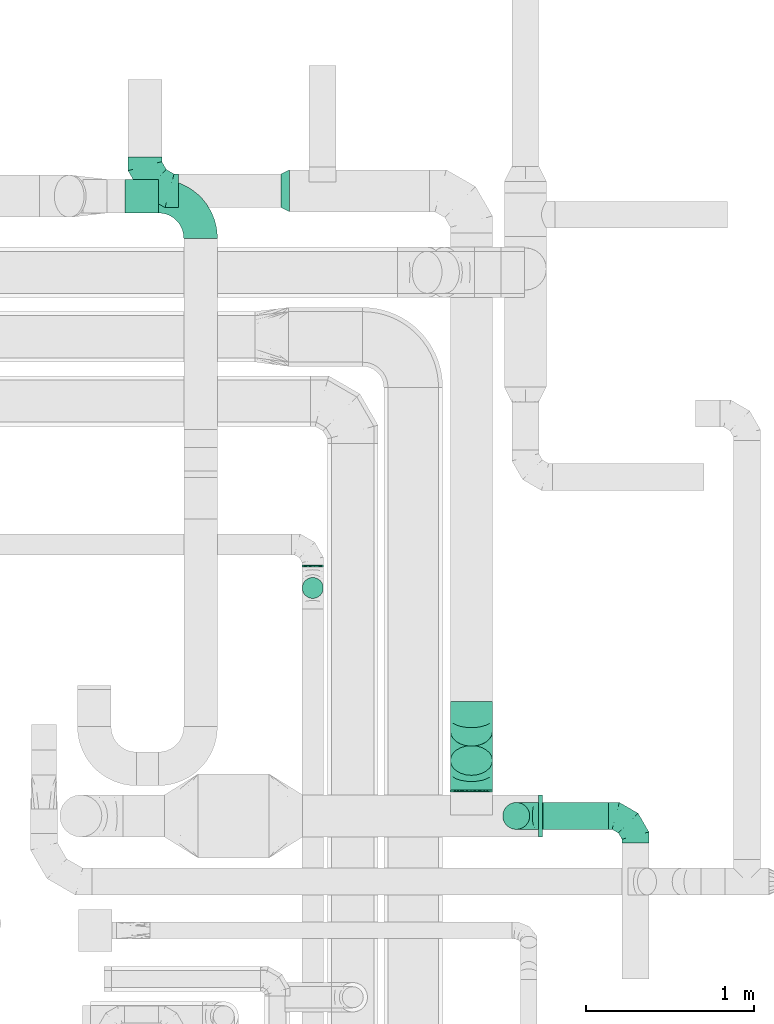
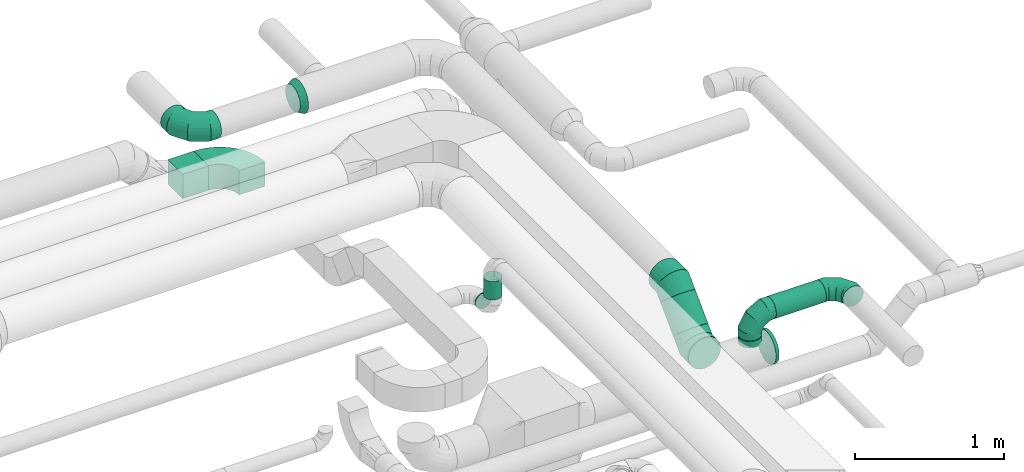
# One storey, part 72 of 92: 9 flow fittings, 7 flow segments.
"""IFC2X3 building model written with IfcOpenShell, lengths in millimetres."""

from ifc_helpers import new_model, entity, si_unit, converted_unit, derived_unit, direction, frame, frame_2d, origin, origin_2d_with_axis, place, context, subcontext, project, spatial, polyline, circle_curve, parameter, trimmed, segment, composite_curve, rectangle, circle, outline, extrude, faceted_brep, source, transform, mapped, material, type_object, type_shapes, element, save


model = new_model("IFC2X3")

# Units and contexts
model_context = context("Model", 3, precision=0.01, world=origin(), true_north=direction((6.12303176911189e-17, 1.0)))
body_context = subcontext(model_context, "Body", "Model", "MODEL_VIEW")
ifc_project = project(units=[si_unit("LENGTHUNIT", "METRE", prefix="MILLI"), si_unit("AREAUNIT", "SQUARE_METRE"), si_unit("VOLUMEUNIT", "CUBIC_METRE"), converted_unit("PLANEANGLEUNIT", "DEGREE", entity("IfcRatioMeasure", 0.0174532925199433), si_unit("PLANEANGLEUNIT", "RADIAN"), dimensions=[0, 0, 0, 0, 0, 0, 0]), si_unit("MASSUNIT", "GRAM", prefix="KILO"), derived_unit("MASSDENSITYUNIT", [(si_unit("MASSUNIT", "GRAM", prefix="KILO"), 1), (si_unit("LENGTHUNIT", "METRE"), -3)]), derived_unit("MOMENTOFINERTIAUNIT", [(si_unit("LENGTHUNIT", "METRE"), 4)]), si_unit("TIMEUNIT", "SECOND"), si_unit("FREQUENCYUNIT", "HERTZ"), si_unit("THERMODYNAMICTEMPERATUREUNIT", "DEGREE_CELSIUS"), derived_unit("THERMALTRANSMITTANCEUNIT", [(si_unit("MASSUNIT", "GRAM", prefix="KILO"), 1), (si_unit("THERMODYNAMICTEMPERATUREUNIT", "KELVIN"), -1), (si_unit("TIMEUNIT", "SECOND"), -3)]), derived_unit("VOLUMETRICFLOWRATEUNIT", [(si_unit("LENGTHUNIT", "METRE"), 3), (si_unit("TIMEUNIT", "SECOND"), -1)]), derived_unit("MASSFLOWRATEUNIT", [(si_unit("MASSUNIT", "GRAM", prefix="KILO"), 1), (si_unit("TIMEUNIT", "SECOND"), -1)]), derived_unit("ROTATIONALFREQUENCYUNIT", [(si_unit("TIMEUNIT", "SECOND"), -1)]), si_unit("ELECTRICCURRENTUNIT", "AMPERE"), si_unit("ELECTRICVOLTAGEUNIT", "VOLT"), si_unit("POWERUNIT", "WATT"), si_unit("FORCEUNIT", "NEWTON", prefix="KILO"), si_unit("ILLUMINANCEUNIT", "LUX"), si_unit("LUMINOUSFLUXUNIT", "LUMEN"), si_unit("LUMINOUSINTENSITYUNIT", "CANDELA"), derived_unit("USERDEFINED", [(si_unit("MASSUNIT", "GRAM", prefix="KILO"), -1), (si_unit("LENGTHUNIT", "METRE"), -2), (si_unit("TIMEUNIT", "SECOND"), 3), (si_unit("LUMINOUSFLUXUNIT", "LUMEN"), 1)]), derived_unit("LINEARVELOCITYUNIT", [(si_unit("LENGTHUNIT", "METRE"), 1), (si_unit("TIMEUNIT", "SECOND"), -1)]), si_unit("PRESSUREUNIT", "PASCAL"), derived_unit("USERDEFINED", [(si_unit("LENGTHUNIT", "METRE"), -2), (si_unit("MASSUNIT", "GRAM", prefix="KILO"), 1), (si_unit("TIMEUNIT", "SECOND"), -2)]), derived_unit("LINEARFORCEUNIT", [(si_unit("MASSUNIT", "GRAM", prefix="KILO"), 1), (si_unit("LENGTHUNIT", "METRE"), 1), (si_unit("TIMEUNIT", "SECOND"), -2), (si_unit("LENGTHUNIT", "METRE"), -1)]), derived_unit("PLANARFORCEUNIT", [(si_unit("MASSUNIT", "GRAM", prefix="KILO"), 1), (si_unit("LENGTHUNIT", "METRE"), 1), (si_unit("TIMEUNIT", "SECOND"), -2), (si_unit("LENGTHUNIT", "METRE"), -2)])], contexts=[model_context])

# Site, building, storey
site_placement = place(None, origin())
site = spatial("IfcSite", under=ifc_project, at=site_placement, CompositionType="ELEMENT")
building_placement = place(site_placement, origin())
building = spatial("IfcBuilding", under=site, at=building_placement, CompositionType="ELEMENT")
storey_placement = place(building_placement, frame((0.0, 0.0, 4200.0)))
storey = spatial("IfcBuildingStorey", under=building, at=storey_placement, CompositionType="ELEMENT", Elevation=4200.0)

# Flow segments
duct_segment_type_1 = type_object("IfcDuctSegmentType", PredefinedType="NOTDEFINED")
flow_segment_1_placement = place(storey_placement, frame((59731.37, 16074.48, 2900.0)))
element("IfcFlowSegment", 1, at=flow_segment_1_placement, inside=storey, type_object=duct_segment_type_1, context=body_context, shape_type="SweptSolid", body=[
    extrude(rectangle(XDim=200.186997811014, YDim=200.0, at=origin_2d_with_axis()), frame((100.09, 100.0, 0.0), z_axis=(0.0, 0.0, 1.0), x_axis=(-1.0, 0.0, 0.0)), (0.0, 0.0, 1.0), 200.0),
])
duct_segment_type_2 = type_object("IfcDuctSegmentType", PredefinedType="NOTDEFINED")
flow_segment_2_placement = place(storey_placement, frame((62215.95, 12412.12, 3228.4)))
element("IfcFlowSegment", 2, at=flow_segment_2_placement, inside=storey, type_object=duct_segment_type_2, context=body_context, shape_type="SweptSolid", body=[
    extrude(circle(Radius=80.0, at=origin_2d_with_axis()), frame((0.0, 81.6, 81.6), z_axis=(1.0, 0.0, 0.0), x_axis=(0.0, 1.0, 0.0)), (0.0, 0.0, 1.0), 388.115615299781),
])
flow_segment_3_placement = place(storey_placement, frame((60783.3, 13972.55, 2885.9)))
element("IfcFlowSegment", 3, at=flow_segment_3_placement, inside=storey, type_object=duct_segment_type_2, context=body_context, shape_type="SweptSolid", body=[
    extrude(circle(Radius=62.5, at=origin_2d_with_axis()), frame((64.1, 0.0, 64.1), z_axis=(0.0, 1.0, 0.0), x_axis=(-1.0, 0.0, 0.0)), (0.0, 0.0, 1.0), 8.73030929463088),
])
flow_segment_4_placement = place(storey_placement, frame((60783.3, 13783.46, 3075.0)))
element("IfcFlowSegment", 4, at=flow_segment_4_placement, inside=storey, type_object=duct_segment_type_2, context=body_context, shape_type="SweptSolid", body=[
    extrude(circle(Radius=62.5, at=origin_2d_with_axis()), frame((64.1, 64.1, 0.0)), (0.0, 0.0, 1.0), 150.000000000007),
])
flow_segment_5_placement = place(storey_placement, frame((61663.4, 12638.72, 2873.4)))
element("IfcFlowSegment", 5, at=flow_segment_5_placement, inside=storey, type_object=duct_segment_type_2, context=body_context, shape_type="SweptSolid", body=[
    extrude(circle(Radius=125.0, at=origin_2d_with_axis()), frame((126.6, 0.0, 126.6), z_axis=(0.0, 1.0, 0.0), x_axis=(1.0, 0.0, 0.0)), (0.0, 0.0, 1.0), 7.53183894146752),
])
flow_segment_6_placement = place(storey_placement, frame((61663.4, 12733.04, 2983.24)))
element("IfcFlowSegment", 6, at=flow_segment_6_placement, inside=storey, type_object=duct_segment_type_2, context=body_context, shape_type="SweptSolid", body=[
    extrude(circle(Radius=125.0, at=origin_2d_with_axis()), frame((126.6, 89.98, 89.98), z_axis=(0.0, 0.707106781186552, 0.707106781186543), x_axis=(1.0, 0.0, 0.0)), (0.0, 0.0, 1.0), 245.442110322462),
])
flow_segment_7_placement = place(storey_placement, frame((61974.35, 12412.12, 3145.0)))
element("IfcFlowSegment", 7, at=flow_segment_7_placement, inside=storey, type_object=duct_segment_type_2, context=body_context, shape_type="SweptSolid", body=[
    extrude(circle(Radius=80.0, at=origin_2d_with_axis()), frame((81.6, 81.6, 0.0), z_axis=(0.0, 0.0, 1.0), x_axis=(0.0, 1.0, 0.0)), (0.0, 0.0, 1.0), 4.99960129249847),
])

# Flow fittings
ifc_material = material()
duct_fitting_type_1 = type_object("IfcDuctFittingType", PredefinedType="NOTDEFINED", material=ifc_material)
shared_shape_1 = source(origin(), body_context, "Body", "SweptSolid", [
    extrude(circle(Radius=124.999999999999, at=origin_2d_with_axis()), frame((0.0, 0.0, 0.0), z_axis=(1.0, 0.0, 0.0), x_axis=(0.0, 1.0, 0.0)), (0.0, 0.0, 1.0), 25.0000000000018),
])
type_shapes(duct_fitting_type_1, [shared_shape_1])
flow_fitting_1_placement = place(storey_placement, frame((62187.28, 12493.72, 3000.0)))
element("IfcFlowFitting", 8, at=flow_fitting_1_placement, inside=storey, type_object=duct_fitting_type_1, material=ifc_material, context=body_context, shape_type="MappedRepresentation", body=[
    mapped(shared_shape_1, transform((0.0, 0.0, 0.0), scale=1.0)),
])
duct_fitting_type_2 = type_object("IfcDuctFittingType", PredefinedType="NOTDEFINED", material=ifc_material)
shared_shape_2 = source(origin(), body_context, "Body", "Brep", [
    faceted_brep([(-160.0, 0.0, -80.0), (-160.0, -20.71, -77.27), (-160.0, -40.0, -69.28), (-160.0, -56.57, -56.57), (-160.0, -69.28, -40.0), (-160.0, -77.27, -20.71), (-160.0, -80.0, 0.0), (-160.0, -77.27, 20.71), (-160.0, -69.28, 40.0), (-160.0, -56.57, 56.57), (-160.0, -40.0, 69.28), (-160.0, -20.71, 77.27), (-160.0, 0.0, 80.0), (-160.0, 20.71, 77.27), (-160.0, 40.0, 69.28), (-160.0, 56.57, 56.57), (-160.0, 69.28, 40.0), (-160.0, 77.27, 20.71), (-160.0, 80.0, 0.0), (-160.0, 77.27, -20.71), (-160.0, 69.28, -40.0), (-160.0, 56.57, -56.57), (-160.0, 40.0, -69.28), (-160.0, 20.71, -77.27), (-122.68, 20.71, 77.27), (-127.85, 40.0, 69.28), (-117.13, 0.0, 80.0), (-132.29, 56.57, 56.57), (-137.83, 77.27, 20.71), (-138.56, 80.0, 0.0), (-135.69, 69.28, 40.0), (-135.69, 69.28, -40.0), (-132.29, 56.57, -56.57), (-137.83, 77.27, -20.71), (-122.68, 20.71, -77.27), (-117.13, 0.0, -80.0), (-127.85, 40.0, -69.28), (-111.58, -20.71, -77.27), (-106.41, -40.0, -69.28), (-101.97, -56.57, -56.57), (-98.56, -69.28, -40.0), (-96.42, -77.27, -20.71), (-95.69, -80.0, 0.0), (-96.42, -77.27, 20.71), (-98.56, -69.28, 40.0), (-101.97, -56.57, 56.57), (-106.41, -40.0, 69.28), (-111.58, -20.71, 77.27), (-58.03, 58.03, 77.27), (-72.15, 72.15, 69.28), (-42.87, 42.87, 80.0), (-84.28, 84.28, 56.57), (-93.59, 93.59, 40.0), (-99.44, 99.44, 20.71), (-101.44, 101.44, 0.0), (-99.44, 99.44, -20.71), (-93.59, 93.59, -40.0), (-84.28, 84.28, -56.57), (-58.03, 58.03, -77.27), (-42.87, 42.87, -80.0), (-72.15, 72.15, -69.28), (-27.71, 27.71, -77.27), (-13.59, 13.59, -69.28), (-1.46, 1.46, -56.57), (7.85, -7.85, -40.0), (13.7, -13.7, -20.71), (15.69, -15.69, 0.0), (13.7, -13.7, 20.71), (7.85, -7.85, 40.0), (-1.46, 1.46, 56.57), (-13.59, 13.59, 69.28), (-27.71, 27.71, 77.27), (-20.71, 122.68, 77.27), (-40.0, 127.85, 69.28), (0.0, 117.13, 80.0), (-56.57, 132.29, 56.57), (-69.28, 135.69, 40.0), (-77.27, 137.83, 20.71), (-80.0, 138.56, 0.0), (-77.27, 137.83, -20.71), (-69.28, 135.69, -40.0), (-56.57, 132.29, -56.57), (-20.71, 122.68, -77.27), (0.0, 117.13, -80.0), (-40.0, 127.85, -69.28), (20.71, 111.58, -77.27), (40.0, 106.41, -69.28), (56.57, 101.97, -56.57), (69.28, 98.56, -40.0), (77.27, 96.42, -20.71), (80.0, 95.69, 0.0), (77.27, 96.42, 20.71), (69.28, 98.56, 40.0), (56.57, 101.97, 56.57), (40.0, 106.41, 69.28), (20.71, 111.58, 77.27), (-20.71, 160.0, -77.27), (-40.0, 160.0, -69.28), (-56.57, 160.0, -56.57), (-69.28, 160.0, -40.0), (-77.27, 160.0, -20.71), (-80.0, 160.0, 0.0), (-77.27, 160.0, 20.71), (-69.28, 160.0, 40.0), (-56.57, 160.0, 56.57), (-40.0, 160.0, 69.28), (-20.71, 160.0, 77.27), (0.0, 160.0, 80.0), (20.71, 160.0, 77.27), (40.0, 160.0, 69.28), (56.57, 160.0, 56.57), (69.28, 160.0, 40.0), (77.27, 160.0, 20.71), (80.0, 160.0, 0.0), (77.27, 160.0, -20.71), (69.28, 160.0, -40.0), (56.57, 160.0, -56.57), (40.0, 160.0, -69.28), (20.71, 160.0, -77.27), (0.0, 160.0, -80.0)], [[[0, 1, 2, 3, 4, 5, 6, 7, 8, 9, 10, 11, 12, 13, 14, 15, 16, 17, 18, 19, 20, 21, 22, 23]], [[24, 25, 14, 13]], [[26, 24, 13, 12]], [[14, 25, 27, 15]], [[28, 29, 18, 17]], [[30, 28, 17, 16]], [[15, 27, 30, 16]], [[20, 31, 32, 21]], [[33, 31, 20, 19]], [[18, 29, 33, 19]], [[34, 35, 0, 23]], [[36, 34, 23, 22]], [[32, 36, 22, 21]], [[1, 0, 35, 37]], [[2, 1, 37, 38]], [[3, 2, 38, 39]], [[5, 4, 40, 41]], [[6, 5, 41, 42]], [[39, 40, 4, 3]], [[6, 42, 43, 7]], [[7, 43, 44, 8]], [[8, 44, 45, 9]], [[9, 45, 46, 10]], [[10, 46, 47, 11]], [[26, 12, 11, 47]], [[48, 49, 25, 24]], [[50, 48, 24, 26]], [[27, 25, 49, 51]], [[52, 53, 28, 30]], [[51, 52, 30, 27]], [[29, 28, 53, 54]], [[55, 56, 31, 33]], [[54, 55, 33, 29]], [[32, 31, 56, 57]], [[58, 59, 35, 34]], [[60, 58, 34, 36]], [[57, 60, 36, 32]], [[37, 35, 59, 61]], [[38, 37, 61, 62]], [[39, 38, 62, 63]], [[41, 40, 64, 65]], [[42, 41, 65, 66]], [[63, 64, 40, 39]], [[43, 42, 66, 67]], [[44, 43, 67, 68]], [[68, 69, 45, 44]], [[46, 45, 69, 70]], [[47, 46, 70, 71]], [[26, 47, 71, 50]], [[72, 73, 49, 48]], [[74, 72, 48, 50]], [[51, 49, 73, 75]], [[76, 77, 53, 52]], [[75, 76, 52, 51]], [[54, 53, 77, 78]], [[79, 80, 56, 55]], [[78, 79, 55, 54]], [[57, 56, 80, 81]], [[82, 83, 59, 58]], [[84, 82, 58, 60]], [[81, 84, 60, 57]], [[61, 59, 83, 85]], [[62, 61, 85, 86]], [[63, 62, 86, 87]], [[65, 64, 88, 89]], [[66, 65, 89, 90]], [[87, 88, 64, 63]], [[67, 66, 90, 91]], [[68, 67, 91, 92]], [[92, 93, 69, 68]], [[70, 69, 93, 94]], [[71, 70, 94, 95]], [[50, 71, 95, 74]], [[96, 97, 98, 99, 100, 101, 102, 103, 104, 105, 106, 107, 108, 109, 110, 111, 112, 113, 114, 115, 116, 117, 118, 119]], [[72, 74, 107, 106]], [[73, 72, 106, 105]], [[75, 73, 105, 104]], [[77, 76, 103, 102]], [[78, 77, 102, 101]], [[75, 104, 103, 76]], [[78, 101, 100, 79]], [[79, 100, 99, 80]], [[80, 99, 98, 81]], [[84, 97, 96, 82]], [[82, 96, 119, 83]], [[84, 81, 98, 97]], [[118, 117, 86, 85]], [[119, 118, 85, 83]], [[116, 87, 86, 117]], [[88, 115, 114, 89]], [[89, 114, 113, 90]], [[115, 88, 87, 116]], [[112, 111, 92, 91]], [[113, 112, 91, 90]], [[111, 110, 93, 92]], [[95, 94, 109, 108]], [[74, 95, 108, 107]], [[110, 109, 94, 93]]]),
])
type_shapes(duct_fitting_type_2, [shared_shape_2])
for number, where, z_axis, x_axis in (
    (9, (62055.95, 12493.72, 3310.0), (0.0, -1.0, 0.0), (-1.0, 0.0, 0.0)),
    (10, (62764.06, 12493.72, 3310.0), (0.0, 0.0, 1.0), (0.0, 1.0, 0.0)),
):
    element("IfcFlowFitting", number, at=place(storey_placement, frame(where, z_axis=z_axis, x_axis=x_axis)), inside=storey, type_object=duct_fitting_type_2, material=ifc_material, context=body_context, shape_type="MappedRepresentation", body=[
        mapped(shared_shape_2, transform((0.0, 0.0, 0.0), scale=1.0)),
    ])
duct_fitting_type_3 = type_object("IfcDuctFittingType", PredefinedType="NOTDEFINED", material=ifc_material)
shared_shape_3 = source(origin(), body_context, "Body", "Brep", [
    faceted_brep([(-200.0, 0.0, -100.0), (-200.0, -25.88, -96.59), (-200.0, -50.0, -86.6), (-200.0, -70.71, -70.71), (-200.0, -86.6, -50.0), (-200.0, -96.59, -25.88), (-200.0, -100.0, 0.0), (-200.0, -96.59, 25.88), (-200.0, -86.6, 50.0), (-200.0, -70.71, 70.71), (-200.0, -50.0, 86.6), (-200.0, -25.88, 96.59), (-200.0, 0.0, 100.0), (-200.0, 25.88, 96.59), (-200.0, 50.0, 86.6), (-200.0, 70.71, 70.71), (-200.0, 86.6, 50.0), (-200.0, 96.59, 25.88), (-200.0, 100.0, 0.0), (-200.0, 96.59, -25.88), (-200.0, 86.6, -50.0), (-200.0, 70.71, -70.71), (-200.0, 50.0, -86.6), (-200.0, 25.88, -96.59), (-153.35, 25.88, 96.59), (-159.81, 50.0, 86.6), (-146.41, 0.0, 100.0), (-165.36, 70.71, 70.71), (-172.29, 96.59, 25.88), (-173.21, 100.0, 0.0), (-169.62, 86.6, 50.0), (-169.62, 86.6, -50.0), (-165.36, 70.71, -70.71), (-172.29, 96.59, -25.88), (-153.35, 25.88, -96.59), (-146.41, 0.0, -100.0), (-159.81, 50.0, -86.6), (-139.48, -25.88, -96.59), (-133.01, -50.0, -86.6), (-127.46, -70.71, -70.71), (-123.21, -86.6, -50.0), (-120.53, -96.59, -25.88), (-119.62, -100.0, 0.0), (-120.53, -96.59, 25.88), (-123.21, -86.6, 50.0), (-127.46, -70.71, 70.71), (-133.01, -50.0, 86.6), (-139.48, -25.88, 96.59), (-72.54, 72.54, 96.59), (-90.19, 90.19, 86.6), (-53.59, 53.59, 100.0), (-105.35, 105.35, 70.71), (-116.99, 116.99, 50.0), (-124.3, 124.3, 25.88), (-126.79, 126.79, 0.0), (-124.3, 124.3, -25.88), (-116.99, 116.99, -50.0), (-105.35, 105.35, -70.71), (-72.54, 72.54, -96.59), (-53.59, 53.59, -100.0), (-90.19, 90.19, -86.6), (-34.64, 34.64, -96.59), (-16.99, 16.99, -86.6), (-1.83, 1.83, -70.71), (9.81, -9.81, -50.0), (17.12, -17.12, -25.88), (19.62, -19.62, 0.0), (17.12, -17.12, 25.88), (9.81, -9.81, 50.0), (-1.83, 1.83, 70.71), (-16.99, 16.99, 86.6), (-34.64, 34.64, 96.59), (-25.88, 153.35, 96.59), (-50.0, 159.81, 86.6), (0.0, 146.41, 100.0), (-70.71, 165.36, 70.71), (-86.6, 169.62, 50.0), (-96.59, 172.29, 25.88), (-100.0, 173.21, 0.0), (-96.59, 172.29, -25.88), (-86.6, 169.62, -50.0), (-70.71, 165.36, -70.71), (-25.88, 153.35, -96.59), (0.0, 146.41, -100.0), (-50.0, 159.81, -86.6), (25.88, 139.48, -96.59), (50.0, 133.01, -86.6), (70.71, 127.46, -70.71), (86.6, 123.21, -50.0), (96.59, 120.53, -25.88), (100.0, 119.62, 0.0), (96.59, 120.53, 25.88), (86.6, 123.21, 50.0), (70.71, 127.46, 70.71), (50.0, 133.01, 86.6), (25.88, 139.48, 96.59), (-25.88, 200.0, -96.59), (-50.0, 200.0, -86.6), (-70.71, 200.0, -70.71), (-86.6, 200.0, -50.0), (-96.59, 200.0, -25.88), (-100.0, 200.0, 0.0), (-96.59, 200.0, 25.88), (-86.6, 200.0, 50.0), (-70.71, 200.0, 70.71), (-50.0, 200.0, 86.6), (-25.88, 200.0, 96.59), (0.0, 200.0, 100.0), (25.88, 200.0, 96.59), (50.0, 200.0, 86.6), (70.71, 200.0, 70.71), (86.6, 200.0, 50.0), (96.59, 200.0, 25.88), (100.0, 200.0, 0.0), (96.59, 200.0, -25.88), (86.6, 200.0, -50.0), (70.71, 200.0, -70.71), (50.0, 200.0, -86.6), (25.88, 200.0, -96.59), (0.0, 200.0, -100.0)], [[[0, 1, 2, 3, 4, 5, 6, 7, 8, 9, 10, 11, 12, 13, 14, 15, 16, 17, 18, 19, 20, 21, 22, 23]], [[24, 25, 14, 13]], [[26, 24, 13, 12]], [[14, 25, 27, 15]], [[28, 29, 18, 17]], [[30, 28, 17, 16]], [[15, 27, 30, 16]], [[20, 31, 32, 21]], [[33, 31, 20, 19]], [[18, 29, 33, 19]], [[34, 35, 0, 23]], [[36, 34, 23, 22]], [[32, 36, 22, 21]], [[1, 0, 35, 37]], [[2, 1, 37, 38]], [[38, 39, 3, 2]], [[5, 4, 40, 41]], [[6, 5, 41, 42]], [[39, 40, 4, 3]], [[6, 42, 43, 7]], [[7, 43, 44, 8]], [[8, 44, 45, 9]], [[9, 45, 46, 10]], [[10, 46, 47, 11]], [[26, 12, 11, 47]], [[48, 49, 25, 24]], [[50, 48, 24, 26]], [[27, 25, 49, 51]], [[52, 53, 28, 30]], [[51, 52, 30, 27]], [[29, 28, 53, 54]], [[55, 56, 31, 33]], [[54, 55, 33, 29]], [[32, 31, 56, 57]], [[58, 59, 35, 34]], [[60, 58, 34, 36]], [[57, 60, 36, 32]], [[37, 35, 59, 61]], [[38, 37, 61, 62]], [[39, 38, 62, 63]], [[41, 40, 64, 65]], [[42, 41, 65, 66]], [[63, 64, 40, 39]], [[43, 42, 66, 67]], [[44, 43, 67, 68]], [[68, 69, 45, 44]], [[46, 45, 69, 70]], [[47, 46, 70, 71]], [[26, 47, 71, 50]], [[72, 73, 49, 48]], [[74, 72, 48, 50]], [[51, 49, 73, 75]], [[76, 77, 53, 52]], [[75, 76, 52, 51]], [[54, 53, 77, 78]], [[79, 80, 56, 55]], [[78, 79, 55, 54]], [[57, 56, 80, 81]], [[82, 83, 59, 58]], [[84, 82, 58, 60]], [[81, 84, 60, 57]], [[61, 59, 83, 85]], [[62, 61, 85, 86]], [[63, 62, 86, 87]], [[65, 64, 88, 89]], [[66, 65, 89, 90]], [[87, 88, 64, 63]], [[67, 66, 90, 91]], [[68, 67, 91, 92]], [[92, 93, 69, 68]], [[70, 69, 93, 94]], [[71, 70, 94, 95]], [[50, 71, 95, 74]], [[96, 97, 98, 99, 100, 101, 102, 103, 104, 105, 106, 107, 108, 109, 110, 111, 112, 113, 114, 115, 116, 117, 118, 119]], [[72, 74, 107, 106]], [[73, 72, 106, 105]], [[75, 73, 105, 104]], [[102, 101, 78, 77]], [[103, 102, 77, 76]], [[75, 104, 103, 76]], [[78, 101, 100, 79]], [[79, 100, 99, 80]], [[80, 99, 98, 81]], [[84, 97, 96, 82]], [[82, 96, 119, 83]], [[84, 81, 98, 97]], [[118, 117, 86, 85]], [[119, 118, 85, 83]], [[116, 87, 86, 117]], [[88, 115, 114, 89]], [[89, 114, 113, 90]], [[115, 88, 87, 116]], [[91, 90, 113, 112]], [[92, 91, 112, 111]], [[111, 110, 93, 92]], [[95, 94, 109, 108]], [[74, 95, 108, 107]], [[110, 109, 94, 93]]]),
])
type_shapes(duct_fitting_type_3, [shared_shape_3])
flow_fitting_2_placement = place(storey_placement, frame((59850.74, 16206.22, 3320.0), z_axis=(0.0, 0.0, 1.0), x_axis=(0.0, -1.0, 0.0)))
element("IfcFlowFitting", 11, at=flow_fitting_2_placement, inside=storey, type_object=duct_fitting_type_3, material=ifc_material, context=body_context, shape_type="MappedRepresentation", body=[
    mapped(shared_shape_3, transform((0.0, 0.0, 0.0), scale=1.0)),
])
duct_fitting_type_4 = type_object("IfcDuctFittingType", PredefinedType="NOTDEFINED", material=ifc_material)
shared_shape_4 = source(origin(), body_context, "Body", "Brep", [
    faceted_brep([(50.0, 80.9, -58.78), (50.0, 95.11, -30.9), (50.0, 100.0, 0.0), (50.0, 95.11, 30.9), (50.0, 80.9, 58.78), (50.0, 58.78, 80.9), (50.0, 30.9, 95.11), (50.0, 0.0, 100.0), (50.0, -30.9, 95.11), (50.0, -58.78, 80.9), (50.0, -80.9, 58.78), (50.0, -95.11, 30.9), (50.0, -100.0, 0.0), (50.0, -95.11, -30.9), (50.0, -80.9, -58.78), (50.0, -58.78, -80.9), (50.0, -30.9, -95.11), (50.0, 0.0, -100.0), (50.0, 30.9, -95.11), (50.0, 58.78, -80.9), (0.0, -125.0, 0.0), (0.0, -118.88, 38.63), (0.0, -101.13, 73.47), (0.0, -73.47, 101.13), (0.0, -38.63, 118.88), (0.0, 0.0, 125.0), (0.0, 38.63, 118.88), (0.0, 73.47, 101.13), (0.0, 101.13, 73.47), (0.0, 118.88, 38.63), (0.0, 125.0, 0.0), (0.0, 118.88, -38.63), (0.0, 101.13, -73.47), (0.0, 73.47, -101.13), (0.0, 38.63, -118.88), (0.0, 0.0, -125.0), (0.0, -38.63, -118.88), (0.0, -73.47, -101.13), (0.0, -101.13, -73.47), (0.0, -118.88, -38.63)], [[[0, 1, 2, 3, 4, 5, 6, 7, 8, 9, 10, 11, 12, 13, 14, 15, 16, 17, 18, 19]], [[20, 21, 22, 23, 24, 25, 26, 27, 28, 29, 30, 31, 32, 33, 34, 35, 36, 37, 38, 39]], [[26, 25, 7, 6]], [[27, 26, 6, 5]], [[5, 4, 28, 27]], [[3, 2, 30, 29]], [[4, 3, 29, 28]], [[21, 20, 12, 11]], [[22, 21, 11, 10]], [[10, 9, 23, 22]], [[8, 7, 25, 24]], [[9, 8, 24, 23]], [[36, 35, 17, 16]], [[37, 36, 16, 15]], [[15, 14, 38, 37]], [[13, 12, 20, 39]], [[14, 13, 39, 38]], [[31, 30, 2, 1]], [[32, 31, 1, 0]], [[0, 19, 33, 32]], [[18, 17, 35, 34]], [[19, 18, 34, 33]]]),
])
type_shapes(duct_fitting_type_4, [shared_shape_4])
flow_fitting_3_placement = place(storey_placement, frame((60710.0, 16206.22, 3320.0), z_axis=(0.0, 0.0, 1.0), x_axis=(-1.0, 0.0, 0.0)))
element("IfcFlowFitting", 12, at=flow_fitting_3_placement, inside=storey, type_object=duct_fitting_type_4, material=ifc_material, context=body_context, shape_type="MappedRepresentation", body=[
    mapped(shared_shape_4, transform((0.0, 0.0, 0.0), scale=1.0)),
])
duct_fitting_type_5 = type_object("IfcDuctFittingType", PredefinedType="NOTDEFINED", material=ifc_material)
shared_shape_5 = source(origin(), body_context, "Body", "Brep", [
    faceted_brep([(-103.55, 0.0, -125.0), (-103.55, -32.35, -120.74), (-103.55, -62.5, -108.25), (-103.55, -88.39, -88.39), (-103.55, -108.25, -62.5), (-103.55, -120.74, -32.35), (-103.55, -125.0, 0.0), (-103.55, -120.74, 32.35), (-103.55, -108.25, 62.5), (-103.55, -88.39, 88.39), (-103.55, -62.5, 108.25), (-103.55, -32.35, 120.74), (-103.55, 0.0, 125.0), (-103.55, 32.35, 120.74), (-103.55, 62.5, 108.25), (-103.55, 88.39, 88.39), (-103.55, 108.25, 62.5), (-103.55, 120.74, 32.35), (-103.55, 125.0, 0.0), (-103.55, 120.74, -32.35), (-103.55, 108.25, -62.5), (-103.55, 88.39, -88.39), (-103.55, 62.5, -108.25), (-103.55, 32.35, -120.74), (-13.4, 32.35, 120.74), (-25.89, 62.5, 108.25), (0.0, 0.0, 125.0), (-36.61, 88.39, 88.39), (-44.84, 108.25, 62.5), (-50.01, 120.74, 32.35), (-51.78, 125.0, 0.0), (-50.01, 120.74, -32.35), (-44.84, 108.25, -62.5), (-36.61, 88.39, -88.39), (-13.4, 32.35, -120.74), (0.0, 0.0, -125.0), (-25.89, 62.5, -108.25), (13.4, -32.35, -120.74), (25.89, -62.5, -108.25), (36.61, -88.39, -88.39), (44.84, -108.25, -62.5), (50.01, -120.74, -32.35), (51.78, -125.0, 0.0), (50.01, -120.74, 32.35), (44.84, -108.25, 62.5), (36.61, -88.39, 88.39), (25.89, -62.5, 108.25), (13.4, -32.35, 120.74), (73.22, 73.22, 125.0), (50.35, 96.1, 120.74), (29.03, 117.42, 108.25), (10.72, 135.72, 88.39), (-3.32, 149.77, 62.5), (-12.15, 158.6, 32.35), (-15.17, 161.61, 0.0), (-12.15, 158.6, -32.35), (-3.32, 149.77, -62.5), (10.72, 135.72, -88.39), (29.03, 117.42, -108.25), (50.35, 96.1, -120.74), (73.22, 73.22, -125.0), (96.1, 50.35, -120.74), (117.42, 29.03, -108.25), (135.72, 10.72, -88.39), (149.77, -3.32, -62.5), (158.6, -12.15, -32.35), (161.61, -15.17, 0.0), (158.6, -12.15, 32.35), (149.77, -3.32, 62.5), (135.72, 10.72, 88.39), (117.42, 29.03, 108.25), (96.1, 50.35, 120.74)], [[[0, 1, 2, 3, 4, 5, 6, 7, 8, 9, 10, 11, 12, 13, 14, 15, 16, 17, 18, 19, 20, 21, 22, 23]], [[24, 25, 14, 13]], [[26, 24, 13, 12]], [[14, 25, 27, 15]], [[28, 29, 17, 16]], [[28, 16, 15, 27]], [[30, 18, 17, 29]], [[31, 32, 20, 19]], [[30, 31, 19, 18]], [[32, 33, 21, 20]], [[34, 35, 0, 23]], [[36, 34, 23, 22]], [[33, 36, 22, 21]], [[1, 0, 35, 37]], [[2, 1, 37, 38]], [[38, 39, 3, 2]], [[5, 4, 40, 41]], [[6, 5, 41, 42]], [[39, 40, 4, 3]], [[6, 42, 43, 7]], [[7, 43, 44, 8]], [[8, 44, 45, 9]], [[9, 45, 46, 10]], [[10, 46, 47, 11]], [[26, 12, 11, 47]], [[24, 26, 48, 49]], [[25, 24, 49, 50]], [[27, 25, 50, 51]], [[29, 28, 52, 53]], [[30, 29, 53, 54]], [[51, 52, 28, 27]], [[30, 54, 55, 31]], [[31, 55, 56, 32]], [[57, 33, 32, 56]], [[36, 58, 59, 34]], [[34, 59, 60, 35]], [[58, 36, 33, 57]], [[35, 60, 61, 37]], [[37, 61, 62, 38]], [[63, 39, 38, 62]], [[40, 64, 65, 41]], [[41, 65, 66, 42]], [[64, 40, 39, 63]], [[43, 42, 66, 67]], [[44, 43, 67, 68]], [[68, 69, 45, 44]], [[47, 46, 70, 71]], [[26, 47, 71, 48]], [[69, 70, 46, 45]], [[59, 58, 57, 56, 55, 54, 53, 52, 51, 50, 49, 48, 71, 70, 69, 68, 67, 66, 65, 64, 63, 62, 61, 60]]]),
])
type_shapes(duct_fitting_type_5, [shared_shape_5])
for number, where, z_axis, x_axis in (
    (13, (61790.0, 12749.8, 3000.0), (1.0, 0.0, 0.0), (0.0, 1.0, 0.0)),
    (14, (61790.0, 13069.8, 3320.0), (-1.0, 0.0, 0.0), (0.0, 0.70710678118651, 0.707106781186585)),
):
    element("IfcFlowFitting", number, at=place(storey_placement, frame(where, z_axis=z_axis, x_axis=x_axis)), inside=storey, type_object=duct_fitting_type_5, material=ifc_material, context=body_context, shape_type="MappedRepresentation", body=[
        mapped(shared_shape_5, transform((0.0, 0.0, 0.0), scale=1.0)),
    ])
duct_fitting_type_6 = type_object("IfcDuctFittingType", PredefinedType="NOTDEFINED", material=ifc_material)
shared_shape_6 = source(origin(), body_context, "Body", "Brep", [
    faceted_brep([(20.0, 0.0, -80.0), (20.0, 20.71, -77.27), (20.0, 40.0, -69.28), (20.0, 56.57, -56.57), (20.0, 69.28, -40.0), (20.0, 77.27, -20.71), (20.0, 80.0, 0.0), (20.0, 77.27, 20.71), (20.0, 69.28, 40.0), (20.0, 56.57, 56.57), (20.0, 40.0, 69.28), (20.0, 20.71, 77.27), (20.0, 0.0, 80.0), (20.0, -20.71, 77.27), (20.0, -40.0, 69.28), (20.0, -56.57, 56.57), (20.0, -69.28, 40.0), (20.0, -77.27, 20.71), (20.0, -80.0, 0.0), (20.0, -77.27, -20.71), (20.0, -69.28, -40.0), (20.0, -56.57, -56.57), (20.0, -40.0, -69.28), (20.0, -20.71, -77.27), (0.0, 0.0, 80.0), (-35.05, 0.0, 80.0), (-35.05, -20.71, 77.27), (0.0, -20.71, 77.27), (-35.05, -40.0, 69.28), (0.0, -40.0, 69.28), (0.0, -56.57, 56.57), (-35.05, -56.57, 56.57), (0.0, -69.28, 40.0), (-35.05, -69.28, 40.0), (-35.05, -77.27, 20.71), (0.0, -77.27, 20.71), (-35.05, -80.0, 0.0), (0.0, -80.0, 0.0), (-35.05, -77.27, -20.71), (0.0, -77.27, -20.71), (-35.05, -69.28, -40.0), (0.0, -69.28, -40.0), (0.0, -56.57, -56.57), (-35.05, -56.57, -56.57), (0.0, -40.0, -69.28), (-35.05, -40.0, -69.28), (-35.05, -20.71, -77.27), (0.0, -20.71, -77.27), (-35.05, 0.0, -80.0), (0.0, 0.0, -80.0), (-35.05, 20.71, -77.27), (0.0, 20.71, -77.27), (-35.05, 40.0, -69.28), (0.0, 40.0, -69.28), (0.0, 56.57, -56.57), (-35.05, 56.57, -56.57), (0.0, 69.28, -40.0), (-35.05, 69.28, -40.0), (-35.05, 77.27, -20.71), (0.0, 77.27, -20.71), (-35.05, 80.0, 0.0), (0.0, 80.0, 0.0), (-35.05, 77.27, 20.71), (0.0, 77.27, 20.71), (-35.05, 69.28, 40.0), (0.0, 69.28, 40.0), (0.0, 56.57, 56.57), (-35.05, 56.57, 56.57), (0.0, 40.0, 69.28), (-35.05, 40.0, 69.28), (-35.05, 20.71, 77.27), (0.0, 20.71, 77.27)], [[[0, 1, 2, 3, 4, 5, 6, 7, 8, 9, 10, 11, 12, 13, 14, 15, 16, 17, 18, 19, 20, 21, 22, 23]], [[13, 12, 24, 25, 26, 27]], [[14, 13, 27, 26, 28, 29]], [[30, 15, 14, 29, 28, 31]], [[17, 16, 32, 33, 34, 35]], [[18, 17, 35, 34, 36, 37]], [[32, 16, 15, 30, 31, 33]], [[19, 18, 37, 36, 38, 39]], [[20, 19, 39, 38, 40, 41]], [[42, 21, 20, 41, 40, 43]], [[23, 22, 44, 45, 46, 47]], [[0, 23, 47, 46, 48, 49]], [[44, 22, 21, 42, 43, 45]], [[1, 0, 49, 48, 50, 51]], [[2, 1, 51, 50, 52, 53]], [[54, 3, 2, 53, 52, 55]], [[5, 4, 56, 57, 58, 59]], [[6, 5, 59, 58, 60, 61]], [[56, 4, 3, 54, 55, 57]], [[7, 6, 61, 60, 62, 63]], [[8, 7, 63, 62, 64, 65]], [[66, 9, 8, 65, 64, 67]], [[11, 10, 68, 69, 70, 71]], [[12, 11, 71, 70, 25, 24]], [[68, 10, 9, 66, 67, 69]], [[46, 45, 43, 40, 38, 36, 34, 33, 31, 28, 26, 25, 70, 69, 67, 64, 62, 60, 58, 57, 55, 52, 50, 48]]]),
])
type_shapes(duct_fitting_type_6, [shared_shape_6])
flow_fitting_4_placement = place(storey_placement, frame((62055.95, 12493.72, 3125.0), z_axis=(1.0, 0.0, 0.0), x_axis=(0.0, 0.0, 1.0)))
element("IfcFlowFitting", 15, at=flow_fitting_4_placement, inside=storey, type_object=duct_fitting_type_6, material=ifc_material, context=body_context, shape_type="MappedRepresentation", body=[
    mapped(shared_shape_6, transform((0.0, 0.0, 0.0), scale=1.0)),
])
duct_fitting_type_7 = type_object("IfcDuctFittingType", PredefinedType="NOTDEFINED", material=ifc_material)
shared_shape_7 = source(origin(), body_context, "Body", "SweptSolid", [
    extrude(outline(composite_curve([segment(polyline([(-225.0, -125.0), (-25.0, -125.0)]), True, "CONTINUOUS"), segment(trimmed(circle_curve(frame_2d((125.0, -125.0), x_axis=(0.0, 1.0)), 150.0), [parameter(0.0)], [parameter(90.0)], True, "PARAMETER"), False, "CONTINUOUS"), segment(polyline([(125.0, 25.0), (125.0, 225.0)]), True, "CONTINUOUS"), segment(trimmed(circle_curve(frame_2d((125.0, -125.0), x_axis=(0.0, 1.0)), 350.0), [parameter(0.0)], [parameter(90.0)], True, "PARAMETER"), True, "CONTINUOUS")], self_intersect=False)), frame((-125.0, 125.0, -100.0), z_axis=(0.0, 0.0, 1.0), x_axis=(-1.0, 0.0, 0.0)), (0.0, 0.0, 1.0), 200.0),
])
type_shapes(duct_fitting_type_7, [shared_shape_7])
flow_fitting_5_placement = place(storey_placement, frame((60181.56, 16174.48, 3000.0), z_axis=(0.0, 0.0, 1.0), x_axis=(0.0, 1.0, 0.0)))
element("IfcFlowFitting", 16, at=flow_fitting_5_placement, inside=storey, type_object=duct_fitting_type_7, material=ifc_material, context=body_context, shape_type="MappedRepresentation", body=[
    mapped(shared_shape_7, transform((0.0, 0.0, 0.0), scale=1.0)),
])

save(model, "model.ifc")
